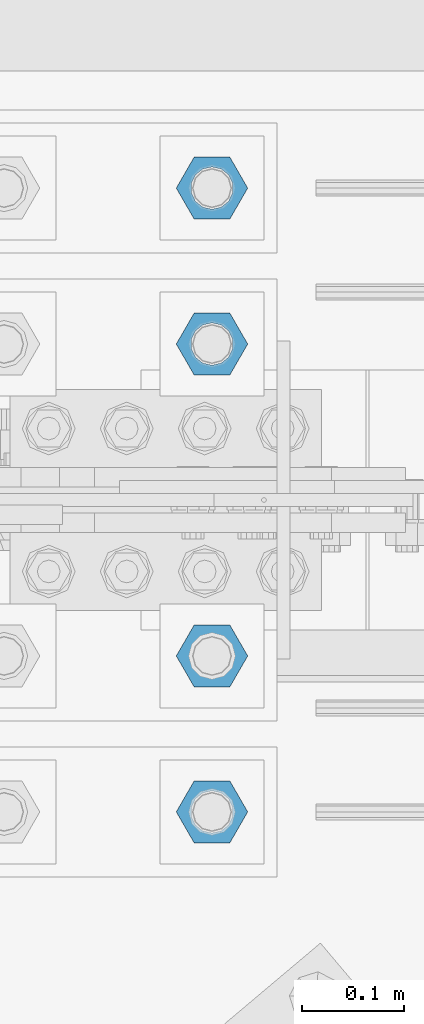
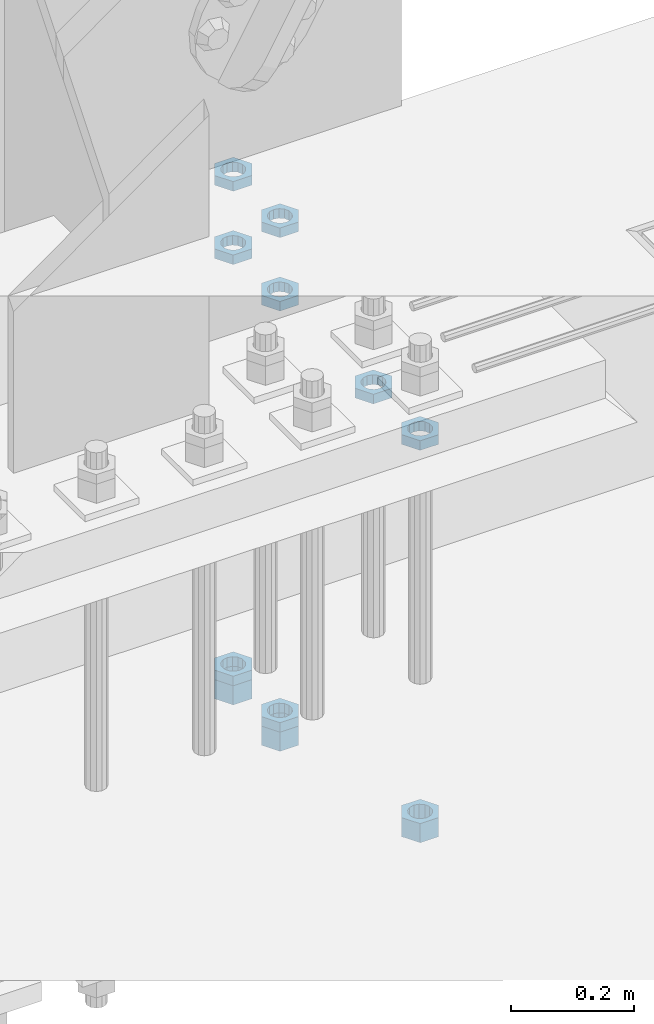
# One storey, part 2882 of 3843: 11 beams, 1 element without a shape of its own.
"""IFC2X3 building model written with IfcOpenShell, lengths in millimetres."""

from ifc_helpers import new_model, si_unit, frame, origin_with_axes, place, context, subcontext, project, spatial, faceted_brep, material, type_object, element, aggregate, save


model = new_model("IFC2X3")

# Units and contexts
model_context = context("Model", 3, precision=1e-05, world=origin_with_axes())
body_context = subcontext(model_context, "Body", "Model", "MODEL_VIEW")
ifc_project = project(units=[si_unit("LENGTHUNIT", "METRE", prefix="MILLI"), si_unit("AREAUNIT", "SQUARE_METRE"), si_unit("VOLUMEUNIT", "CUBIC_METRE"), si_unit("MASSUNIT", "GRAM", prefix="KILO"), si_unit("TIMEUNIT", "SECOND"), si_unit("PLANEANGLEUNIT", "RADIAN"), si_unit("SOLIDANGLEUNIT", "STERADIAN"), si_unit("THERMODYNAMICTEMPERATUREUNIT", "DEGREE_CELSIUS"), si_unit("LUMINOUSINTENSITYUNIT", "LUMEN")], contexts=[model_context])

# Site, building, storey
site_placement = place(None, origin_with_axes())
site = spatial("IfcSite", under=ifc_project, at=site_placement, CompositionType="ELEMENT")
building_placement = place(site_placement, origin_with_axes())
building = spatial("IfcBuilding", under=site, at=building_placement, Name="Undefined", CompositionType="ELEMENT")
storey_placement = place(building_placement, origin_with_axes())
storey = spatial("IfcBuildingStorey", under=building, at=storey_placement, Name="Undefined", CompositionType="ELEMENT", Elevation=0.0)

# Assembly, beams
assembly_placement = place(storey_placement, origin_with_axes())
assembly = element("IfcElementAssembly", 1, at=assembly_placement, inside=storey, Name="TEMPLATE", AssemblyPlace="NOTDEFINED", PredefinedType="RIGID_FRAME")
ifc_material = material(Name="STEEL/A572-50")
beam_type_1 = type_object("IfcBeamType", Name="1-1/2_HEAVY_HEX_NUT", PredefinedType="NOTDEFINED")
beam_1_placement = place(assembly_placement, frame((49504.6, 91909.9, 29298.9000015259), z_axis=(0.0, 1.0, 0.0), x_axis=(0.0, 0.0, -1.0)))
beam_1 = element("IfcBeam", 2, at=beam_1_placement, type_object=beam_type_1, material=ifc_material, Name="NUT", ObjectType="1-1/2_HEAVY_HEX_NUT", context=body_context, shape_type="Brep", body=[
    faceted_brep([(0.0, -34.9199981689453, 0.0), (0.0, -17.4599990844727, -30.25), (38.0999999999985, -17.4599990844727, -30.25), (38.0999999999985, -34.9199981689453, 0.0), (0.0, 17.4599990844727, -30.25), (38.0999999999985, 17.4599990844727, -30.25), (0.0, 34.9199981689453, 0.0), (38.0999999999985, 34.9199981689453, 0.0), (0.0, 17.4599990844727, 30.25), (38.0999999999985, 17.4599990844727, 30.25), (0.0, -17.4599990844727, 30.25), (38.0999999999985, -17.4599990844727, 30.25), (0.0, 0.0, 20.6399993896484), (0.0, 8.9553601105581, 18.5959968835959), (38.0999999999985, 8.9553601105581, 18.5959968835959), (38.0999999999985, 0.0, 20.6399993896484), (0.0, 16.1370013209525, 12.8688291298167), (38.0999999999985, 16.1370013209525, 12.8688291298167), (0.0, 20.1225115123816, 4.59283194104501), (38.0999999999985, 20.1225115123816, 4.59283194104501), (0.0, 20.1225115123816, -4.59283194104501), (38.0999999999985, 20.1225115123816, -4.59283194104501), (0.0, 16.1370013209525, -12.8688291298167), (38.0999999999985, 16.1370013209525, -12.8688291298167), (0.0, 8.9553601105581, -18.5959968835959), (38.0999999999985, 8.9553601105581, -18.5959968835959), (0.0, 0.0, -20.6399993896484), (38.0999999999985, 0.0, -20.6399993896484), (0.0, -8.9553601105581, -18.5959968835959), (38.0999999999985, -8.9553601105581, -18.5959968835959), (0.0, -16.1370013209525, -12.8688291298167), (38.0999999999985, -16.1370013209525, -12.8688291298167), (0.0, -20.1225115123816, -4.59283194104501), (38.0999999999985, -20.1225115123816, -4.59283194104501), (0.0, -20.1225115123816, 4.59283194104501), (38.0999999999985, -20.1225115123816, 4.59283194104501), (0.0, -16.1370013209525, 12.8688291298167), (38.0999999999985, -16.1370013209525, 12.8688291298167), (0.0, -8.9553601105581, 18.5959968835959), (38.0999999999985, -8.9553601105581, 18.5959968835959)], [[[0, 1, 2, 3]], [[1, 4, 5, 2]], [[4, 6, 7, 5]], [[6, 8, 9, 7]], [[8, 10, 11, 9]], [[10, 0, 3, 11]], [[12, 13, 14, 15]], [[13, 16, 17, 14]], [[16, 18, 19, 17]], [[18, 20, 21, 19]], [[20, 22, 23, 21]], [[22, 24, 25, 23]], [[24, 26, 27, 25]], [[26, 28, 29, 27]], [[28, 30, 31, 29]], [[30, 32, 33, 31]], [[32, 34, 35, 33]], [[34, 36, 37, 35]], [[36, 38, 39, 37]], [[38, 12, 15, 39]], [[5, 7, 9, 11, 3, 2], [17, 19, 21, 23, 25, 27, 29, 31, 33, 35, 37, 39, 15, 14]], [[10, 8, 6, 4, 1, 0], [38, 36, 34, 32, 30, 28, 26, 24, 22, 20, 18, 16, 13, 12]]]),
])
beam_2_placement = place(assembly_placement, frame((49504.6, 92519.5, 29203.6500015259), z_axis=(0.0, 1.0, 0.0), x_axis=(0.0, 0.0, -1.0)))
beam_2 = element("IfcBeam", 3, at=beam_2_placement, type_object=beam_type_1, material=ifc_material, Name="NUT", ObjectType="1-1/2_HEAVY_HEX_NUT", context=body_context, shape_type="Brep", body=[
    faceted_brep([(0.0, -34.9199981689453, 0.0), (0.0, -17.4599990844727, -30.25), (38.0999999999985, -17.4599990844727, -30.25), (38.0999999999985, -34.9199981689453, 0.0), (0.0, 17.4599990844727, -30.25), (38.0999999999985, 17.4599990844727, -30.25), (0.0, 34.9199981689453, 0.0), (38.0999999999985, 34.9199981689453, 0.0), (0.0, 17.4599990844727, 30.25), (38.0999999999985, 17.4599990844727, 30.25), (0.0, -17.4599990844727, 30.25), (38.0999999999985, -17.4599990844727, 30.25), (0.0, 0.0, 20.6399993896484), (0.0, 8.9553601105581, 18.5959968835959), (38.0999999999985, 8.9553601105581, 18.5959968835959), (38.0999999999985, 0.0, 20.6399993896484), (0.0, 16.1370013209525, 12.8688291298167), (38.0999999999985, 16.1370013209525, 12.8688291298167), (0.0, 20.1225115123816, 4.59283194104501), (38.0999999999985, 20.1225115123816, 4.59283194104501), (0.0, 20.1225115123816, -4.59283194104501), (38.0999999999985, 20.1225115123816, -4.59283194104501), (0.0, 16.1370013209525, -12.8688291298167), (38.0999999999985, 16.1370013209525, -12.8688291298167), (0.0, 8.9553601105581, -18.5959968835959), (38.0999999999985, 8.9553601105581, -18.5959968835959), (0.0, 0.0, -20.6399993896484), (38.0999999999985, 0.0, -20.6399993896484), (0.0, -8.9553601105581, -18.5959968835959), (38.0999999999985, -8.9553601105581, -18.5959968835959), (0.0, -16.1370013209525, -12.8688291298167), (38.0999999999985, -16.1370013209525, -12.8688291298167), (0.0, -20.1225115123816, -4.59283194104501), (38.0999999999985, -20.1225115123816, -4.59283194104501), (0.0, -20.1225115123816, 4.59283194104501), (38.0999999999985, -20.1225115123816, 4.59283194104501), (0.0, -16.1370013209525, 12.8688291298167), (38.0999999999985, -16.1370013209525, 12.8688291298167), (0.0, -8.9553601105581, 18.5959968835959), (38.0999999999985, -8.9553601105581, 18.5959968835959)], [[[0, 1, 2, 3]], [[1, 4, 5, 2]], [[4, 6, 7, 5]], [[6, 8, 9, 7]], [[8, 10, 11, 9]], [[10, 0, 3, 11]], [[12, 13, 14, 15]], [[13, 16, 17, 14]], [[16, 18, 19, 17]], [[18, 20, 21, 19]], [[20, 22, 23, 21]], [[22, 24, 25, 23]], [[24, 26, 27, 25]], [[26, 28, 29, 27]], [[28, 30, 31, 29]], [[30, 32, 33, 31]], [[32, 34, 35, 33]], [[34, 36, 37, 35]], [[36, 38, 39, 37]], [[38, 12, 15, 39]], [[5, 7, 9, 11, 3, 2], [17, 19, 21, 23, 25, 27, 29, 31, 33, 35, 37, 39, 15, 14]], [[10, 8, 6, 4, 1, 0], [38, 36, 34, 32, 30, 28, 26, 24, 22, 20, 18, 16, 13, 12]]]),
])
beam_3_placement = place(assembly_placement, frame((49504.6, 92367.1, 29203.6500015259), z_axis=(0.0, 1.0, 0.0), x_axis=(0.0, 0.0, -1.0)))
beam_3 = element("IfcBeam", 4, at=beam_3_placement, type_object=beam_type_1, material=ifc_material, Name="NUT", ObjectType="1-1/2_HEAVY_HEX_NUT", context=body_context, shape_type="Brep", body=[
    faceted_brep([(0.0, -34.9199981689453, 0.0), (0.0, -17.4599990844727, -30.25), (38.0999999999985, -17.4599990844727, -30.25), (38.0999999999985, -34.9199981689453, 0.0), (0.0, 17.4599990844727, -30.25), (38.0999999999985, 17.4599990844727, -30.25), (0.0, 34.9199981689453, 0.0), (38.0999999999985, 34.9199981689453, 0.0), (0.0, 17.4599990844727, 30.25), (38.0999999999985, 17.4599990844727, 30.25), (0.0, -17.4599990844727, 30.25), (38.0999999999985, -17.4599990844727, 30.25), (0.0, 0.0, 20.6399993896484), (0.0, 8.9553601105581, 18.5959968835959), (38.0999999999985, 8.9553601105581, 18.5959968835959), (38.0999999999985, 0.0, 20.6399993896484), (0.0, 16.1370013209525, 12.8688291298167), (38.0999999999985, 16.1370013209525, 12.8688291298167), (0.0, 20.1225115123816, 4.59283194104501), (38.0999999999985, 20.1225115123816, 4.59283194104501), (0.0, 20.1225115123816, -4.59283194104501), (38.0999999999985, 20.1225115123816, -4.59283194104501), (0.0, 16.1370013209525, -12.8688291298167), (38.0999999999985, 16.1370013209525, -12.8688291298167), (0.0, 8.9553601105581, -18.5959968835959), (38.0999999999985, 8.9553601105581, -18.5959968835959), (0.0, 0.0, -20.6399993896484), (38.0999999999985, 0.0, -20.6399993896484), (0.0, -8.9553601105581, -18.5959968835959), (38.0999999999985, -8.9553601105581, -18.5959968835959), (0.0, -16.1370013209525, -12.8688291298167), (38.0999999999985, -16.1370013209525, -12.8688291298167), (0.0, -20.1225115123816, -4.59283194104501), (38.0999999999985, -20.1225115123816, -4.59283194104501), (0.0, -20.1225115123816, 4.59283194104501), (38.0999999999985, -20.1225115123816, 4.59283194104501), (0.0, -16.1370013209525, 12.8688291298167), (38.0999999999985, -16.1370013209525, 12.8688291298167), (0.0, -8.9553601105581, 18.5959968835959), (38.0999999999985, -8.9553601105581, 18.5959968835959)], [[[0, 1, 2, 3]], [[1, 4, 5, 2]], [[4, 6, 7, 5]], [[6, 8, 9, 7]], [[8, 10, 11, 9]], [[10, 0, 3, 11]], [[12, 13, 14, 15]], [[13, 16, 17, 14]], [[16, 18, 19, 17]], [[18, 20, 21, 19]], [[20, 22, 23, 21]], [[22, 24, 25, 23]], [[24, 26, 27, 25]], [[26, 28, 29, 27]], [[28, 30, 31, 29]], [[30, 32, 33, 31]], [[32, 34, 35, 33]], [[34, 36, 37, 35]], [[36, 38, 39, 37]], [[38, 12, 15, 39]], [[5, 7, 9, 11, 3, 2], [17, 19, 21, 23, 25, 27, 29, 31, 33, 35, 37, 39, 15, 14]], [[10, 8, 6, 4, 1, 0], [38, 36, 34, 32, 30, 28, 26, 24, 22, 20, 18, 16, 13, 12]]]),
])
beam_type_2 = type_object("IfcBeamType", Name="1-1/2_HALF_NUT", PredefinedType="NOTDEFINED")
beam_4_placement = place(assembly_placement, frame((49504.600012207, 92519.5, 30060.9), z_axis=(0.0, 1.0, 0.0), x_axis=(0.0, 0.0, -1.0)))
beam_4 = element("IfcBeam", 5, at=beam_4_placement, type_object=beam_type_2, material=ifc_material, Name="NUT", ObjectType="1-1/2_HALF_NUT", context=body_context, shape_type="Brep", body=[
    faceted_brep([(0.0, -34.9199981689453, 0.0), (0.0, -17.4599990844727, -30.25), (19.0500000000029, -17.4599990844727, -30.25), (19.0500000000029, -34.9199981689453, 0.0), (0.0, 17.4599990844727, -30.25), (19.0500000000029, 17.4599990844727, -30.25), (0.0, 34.9199981689453, 0.0), (19.0500000000029, 34.9199981689453, 0.0), (0.0, 17.4599990844727, 30.25), (19.0500000000029, 17.4599990844727, 30.25), (0.0, -17.4599990844727, 30.25), (19.0500000000029, -17.4599990844727, 30.25), (0.0, 0.0, 20.6399993896484), (0.0, 8.9553601105581, 18.5959968835959), (19.0500000000029, 8.95536011056538, 18.5959968835959), (19.0500000000029, 0.0, 20.6399993896484), (0.0, 16.1370013209525, 12.8688291298167), (19.0500000000029, 16.1370013209489, 12.8688291298167), (0.0, 20.1225115123816, 4.59283194104501), (19.0500000000029, 20.1225115123852, 4.59283194104501), (0.0, 20.1225115123816, -4.59283194104501), (19.0500000000029, 20.1225115123852, -4.59283194104501), (0.0, 16.1370013209525, -12.8688291298167), (19.0500000000029, 16.1370013209489, -12.8688291298167), (0.0, 8.9553601105581, -18.5959968835959), (19.0500000000029, 8.95536011056538, -18.5959968835959), (0.0, 0.0, -20.6399993896484), (19.0500000000029, 0.0, -20.6399993896484), (0.0, -8.9553601105581, -18.5959968835959), (19.0500000000029, -8.95536011056538, -18.5959968835959), (0.0, -16.1370013209525, -12.8688291298167), (19.0500000000029, -16.1370013209489, -12.8688291298167), (0.0, -20.1225115123816, -4.59283194104501), (19.0500000000029, -20.1225115123852, -4.59283194104501), (0.0, -20.1225115123816, 4.59283194104501), (19.0500000000029, -20.1225115123852, 4.59283194104501), (0.0, -16.1370013209525, 12.8688291298167), (19.0500000000029, -16.1370013209489, 12.8688291298167), (0.0, -8.9553601105581, 18.5959968835959), (19.0500000000029, -8.95536011056538, 18.5959968835959)], [[[0, 1, 2, 3]], [[1, 4, 5, 2]], [[4, 6, 7, 5]], [[6, 8, 9, 7]], [[8, 10, 11, 9]], [[10, 0, 3, 11]], [[12, 13, 14, 15]], [[13, 16, 17, 14]], [[16, 18, 19, 17]], [[18, 20, 21, 19]], [[20, 22, 23, 21]], [[22, 24, 25, 23]], [[24, 26, 27, 25]], [[26, 28, 29, 27]], [[28, 30, 31, 29]], [[30, 32, 33, 31]], [[32, 34, 35, 33]], [[34, 36, 37, 35]], [[36, 38, 39, 37]], [[38, 12, 15, 39]], [[5, 7, 9, 11, 3, 2], [17, 19, 21, 23, 25, 27, 29, 31, 33, 35, 37, 39, 15, 14]], [[10, 8, 6, 4, 1, 0], [38, 36, 34, 32, 30, 28, 26, 24, 22, 20, 18, 16, 13, 12]]]),
])
beam_5_placement = place(assembly_placement, frame((49504.600012207, 92367.1, 30060.9), z_axis=(0.0, 1.0, 0.0), x_axis=(0.0, 0.0, -1.0)))
beam_5 = element("IfcBeam", 6, at=beam_5_placement, type_object=beam_type_2, material=ifc_material, Name="NUT", ObjectType="1-1/2_HALF_NUT", context=body_context, shape_type="Brep", body=[
    faceted_brep([(0.0, -34.9199981689453, 0.0), (0.0, -17.4599990844727, -30.25), (19.0500000000029, -17.4599990844727, -30.25), (19.0500000000029, -34.9199981689453, 0.0), (0.0, 17.4599990844727, -30.25), (19.0500000000029, 17.4599990844727, -30.25), (0.0, 34.9199981689453, 0.0), (19.0500000000029, 34.9199981689453, 0.0), (0.0, 17.4599990844727, 30.25), (19.0500000000029, 17.4599990844727, 30.25), (0.0, -17.4599990844727, 30.25), (19.0500000000029, -17.4599990844727, 30.25), (0.0, 0.0, 20.6399993896484), (0.0, 8.9553601105581, 18.5959968835959), (19.0500000000029, 8.95536011056538, 18.5959968835959), (19.0500000000029, 0.0, 20.6399993896484), (0.0, 16.1370013209525, 12.8688291298167), (19.0500000000029, 16.1370013209489, 12.8688291298167), (0.0, 20.1225115123816, 4.59283194104501), (19.0500000000029, 20.1225115123852, 4.59283194104501), (0.0, 20.1225115123816, -4.59283194104501), (19.0500000000029, 20.1225115123852, -4.59283194104501), (0.0, 16.1370013209525, -12.8688291298167), (19.0500000000029, 16.1370013209489, -12.8688291298167), (0.0, 8.9553601105581, -18.5959968835959), (19.0500000000029, 8.95536011056538, -18.5959968835959), (0.0, 0.0, -20.6399993896484), (19.0500000000029, 0.0, -20.6399993896484), (0.0, -8.9553601105581, -18.5959968835959), (19.0500000000029, -8.95536011056538, -18.5959968835959), (0.0, -16.1370013209525, -12.8688291298167), (19.0500000000029, -16.1370013209489, -12.8688291298167), (0.0, -20.1225115123816, -4.59283194104501), (19.0500000000029, -20.1225115123852, -4.59283194104501), (0.0, -20.1225115123816, 4.59283194104501), (19.0500000000029, -20.1225115123852, 4.59283194104501), (0.0, -16.1370013209525, 12.8688291298167), (19.0500000000029, -16.1370013209489, 12.8688291298167), (0.0, -8.9553601105581, 18.5959968835959), (19.0500000000029, -8.95536011056538, 18.5959968835959)], [[[0, 1, 2, 3]], [[1, 4, 5, 2]], [[4, 6, 7, 5]], [[6, 8, 9, 7]], [[8, 10, 11, 9]], [[10, 0, 3, 11]], [[12, 13, 14, 15]], [[13, 16, 17, 14]], [[16, 18, 19, 17]], [[18, 20, 21, 19]], [[20, 22, 23, 21]], [[22, 24, 25, 23]], [[24, 26, 27, 25]], [[26, 28, 29, 27]], [[28, 30, 31, 29]], [[30, 32, 33, 31]], [[32, 34, 35, 33]], [[34, 36, 37, 35]], [[36, 38, 39, 37]], [[38, 12, 15, 39]], [[5, 7, 9, 11, 3, 2], [17, 19, 21, 23, 25, 27, 29, 31, 33, 35, 37, 39, 15, 14]], [[10, 8, 6, 4, 1, 0], [38, 36, 34, 32, 30, 28, 26, 24, 22, 20, 18, 16, 13, 12]]]),
])
beam_6_placement = place(assembly_placement, frame((49504.600012207, 92062.3, 30060.9), z_axis=(0.0, 1.0, 0.0), x_axis=(0.0, 0.0, -1.0)))
beam_6 = element("IfcBeam", 7, at=beam_6_placement, type_object=beam_type_2, material=ifc_material, Name="NUT", ObjectType="1-1/2_HALF_NUT", context=body_context, shape_type="Brep", body=[
    faceted_brep([(0.0, -34.9199981689453, 0.0), (0.0, -17.4599990844727, -30.25), (19.0500000000029, -17.4599990844727, -30.25), (19.0500000000029, -34.9199981689453, 0.0), (0.0, 17.4599990844727, -30.25), (19.0500000000029, 17.4599990844727, -30.25), (0.0, 34.9199981689453, 0.0), (19.0500000000029, 34.9199981689453, 0.0), (0.0, 17.4599990844727, 30.25), (19.0500000000029, 17.4599990844727, 30.25), (0.0, -17.4599990844727, 30.25), (19.0500000000029, -17.4599990844727, 30.25), (0.0, 0.0, 20.6399993896484), (0.0, 8.9553601105581, 18.5959968835959), (19.0500000000029, 8.95536011056538, 18.5959968835959), (19.0500000000029, 0.0, 20.6399993896484), (0.0, 16.1370013209525, 12.8688291298167), (19.0500000000029, 16.1370013209489, 12.8688291298167), (0.0, 20.1225115123816, 4.59283194104501), (19.0500000000029, 20.1225115123852, 4.59283194104501), (0.0, 20.1225115123816, -4.59283194104501), (19.0500000000029, 20.1225115123852, -4.59283194104501), (0.0, 16.1370013209525, -12.8688291298167), (19.0500000000029, 16.1370013209489, -12.8688291298167), (0.0, 8.9553601105581, -18.5959968835959), (19.0500000000029, 8.95536011056538, -18.5959968835959), (0.0, 0.0, -20.6399993896484), (19.0500000000029, 0.0, -20.6399993896484), (0.0, -8.9553601105581, -18.5959968835959), (19.0500000000029, -8.95536011056538, -18.5959968835959), (0.0, -16.1370013209525, -12.8688291298167), (19.0500000000029, -16.1370013209489, -12.8688291298167), (0.0, -20.1225115123816, -4.59283194104501), (19.0500000000029, -20.1225115123852, -4.59283194104501), (0.0, -20.1225115123816, 4.59283194104501), (19.0500000000029, -20.1225115123852, 4.59283194104501), (0.0, -16.1370013209525, 12.8688291298167), (19.0500000000029, -16.1370013209489, 12.8688291298167), (0.0, -8.9553601105581, 18.5959968835959), (19.0500000000029, -8.95536011056538, 18.5959968835959)], [[[0, 1, 2, 3]], [[1, 4, 5, 2]], [[4, 6, 7, 5]], [[6, 8, 9, 7]], [[8, 10, 11, 9]], [[10, 0, 3, 11]], [[12, 13, 14, 15]], [[13, 16, 17, 14]], [[16, 18, 19, 17]], [[18, 20, 21, 19]], [[20, 22, 23, 21]], [[22, 24, 25, 23]], [[24, 26, 27, 25]], [[26, 28, 29, 27]], [[28, 30, 31, 29]], [[30, 32, 33, 31]], [[32, 34, 35, 33]], [[34, 36, 37, 35]], [[36, 38, 39, 37]], [[38, 12, 15, 39]], [[5, 7, 9, 11, 3, 2], [17, 19, 21, 23, 25, 27, 29, 31, 33, 35, 37, 39, 15, 14]], [[10, 8, 6, 4, 1, 0], [38, 36, 34, 32, 30, 28, 26, 24, 22, 20, 18, 16, 13, 12]]]),
])
beam_7_placement = place(assembly_placement, frame((49504.600012207, 91909.9, 30060.9), z_axis=(0.0, 1.0, 0.0), x_axis=(0.0, 0.0, -1.0)))
beam_7 = element("IfcBeam", 8, at=beam_7_placement, type_object=beam_type_2, material=ifc_material, Name="NUT", ObjectType="1-1/2_HALF_NUT", context=body_context, shape_type="Brep", body=[
    faceted_brep([(0.0, -34.9199981689453, 0.0), (0.0, -17.4599990844727, -30.25), (19.0500000000029, -17.4599990844727, -30.25), (19.0500000000029, -34.9199981689453, 0.0), (0.0, 17.4599990844727, -30.25), (19.0500000000029, 17.4599990844727, -30.25), (0.0, 34.9199981689453, 0.0), (19.0500000000029, 34.9199981689453, 0.0), (0.0, 17.4599990844727, 30.25), (19.0500000000029, 17.4599990844727, 30.25), (0.0, -17.4599990844727, 30.25), (19.0500000000029, -17.4599990844727, 30.25), (0.0, 0.0, 20.6399993896484), (0.0, 8.9553601105581, 18.5959968835959), (19.0500000000029, 8.95536011056538, 18.5959968835959), (19.0500000000029, 0.0, 20.6399993896484), (0.0, 16.1370013209525, 12.8688291298167), (19.0500000000029, 16.1370013209489, 12.8688291298167), (0.0, 20.1225115123816, 4.59283194104501), (19.0500000000029, 20.1225115123852, 4.59283194104501), (0.0, 20.1225115123816, -4.59283194104501), (19.0500000000029, 20.1225115123852, -4.59283194104501), (0.0, 16.1370013209525, -12.8688291298167), (19.0500000000029, 16.1370013209489, -12.8688291298167), (0.0, 8.9553601105581, -18.5959968835959), (19.0500000000029, 8.95536011056538, -18.5959968835959), (0.0, 0.0, -20.6399993896484), (19.0500000000029, 0.0, -20.6399993896484), (0.0, -8.9553601105581, -18.5959968835959), (19.0500000000029, -8.95536011056538, -18.5959968835959), (0.0, -16.1370013209525, -12.8688291298167), (19.0500000000029, -16.1370013209489, -12.8688291298167), (0.0, -20.1225115123816, -4.59283194104501), (19.0500000000029, -20.1225115123852, -4.59283194104501), (0.0, -20.1225115123816, 4.59283194104501), (19.0500000000029, -20.1225115123852, 4.59283194104501), (0.0, -16.1370013209525, 12.8688291298167), (19.0500000000029, -16.1370013209489, 12.8688291298167), (0.0, -8.9553601105581, 18.5959968835959), (19.0500000000029, -8.95536011056538, 18.5959968835959)], [[[0, 1, 2, 3]], [[1, 4, 5, 2]], [[4, 6, 7, 5]], [[6, 8, 9, 7]], [[8, 10, 11, 9]], [[10, 0, 3, 11]], [[12, 13, 14, 15]], [[13, 16, 17, 14]], [[16, 18, 19, 17]], [[18, 20, 21, 19]], [[20, 22, 23, 21]], [[22, 24, 25, 23]], [[24, 26, 27, 25]], [[26, 28, 29, 27]], [[28, 30, 31, 29]], [[30, 32, 33, 31]], [[32, 34, 35, 33]], [[34, 36, 37, 35]], [[36, 38, 39, 37]], [[38, 12, 15, 39]], [[5, 7, 9, 11, 3, 2], [17, 19, 21, 23, 25, 27, 29, 31, 33, 35, 37, 39, 15, 14]], [[10, 8, 6, 4, 1, 0], [38, 36, 34, 32, 30, 28, 26, 24, 22, 20, 18, 16, 13, 12]]]),
])
beam_8_placement = place(assembly_placement, frame((49504.6, 92519.5, 29222.7000015259), z_axis=(0.0, 1.0, 0.0), x_axis=(0.0, 0.0, -1.0)))
beam_8 = element("IfcBeam", 9, at=beam_8_placement, type_object=beam_type_2, material=ifc_material, Name="NUT", ObjectType="1-1/2_HALF_NUT", context=body_context, shape_type="Brep", body=[
    faceted_brep([(0.0, -34.9199981689453, 0.0), (0.0, -17.4599990844727, -30.25), (19.0500000000029, -17.4599990844727, -30.25), (19.0500000000029, -34.9199981689453, 0.0), (0.0, 17.4599990844727, -30.25), (19.0500000000029, 17.4599990844727, -30.25), (0.0, 34.9199981689453, 0.0), (19.0500000000029, 34.9199981689453, 0.0), (0.0, 17.4599990844727, 30.25), (19.0500000000029, 17.4599990844727, 30.25), (0.0, -17.4599990844727, 30.25), (19.0500000000029, -17.4599990844727, 30.25), (0.0, 0.0, 20.6399993896484), (0.0, 8.9553601105581, 18.5959968835959), (19.0500000000029, 8.95536011056538, 18.5959968835959), (19.0500000000029, 0.0, 20.6399993896484), (0.0, 16.1370013209525, 12.8688291298167), (19.0500000000029, 16.1370013209489, 12.8688291298167), (0.0, 20.1225115123816, 4.59283194104501), (19.0500000000029, 20.1225115123852, 4.59283194104501), (0.0, 20.1225115123816, -4.59283194104501), (19.0500000000029, 20.1225115123852, -4.59283194104501), (0.0, 16.1370013209525, -12.8688291298167), (19.0500000000029, 16.1370013209489, -12.8688291298167), (0.0, 8.9553601105581, -18.5959968835959), (19.0500000000029, 8.95536011056538, -18.5959968835959), (0.0, 0.0, -20.6399993896484), (19.0500000000029, 0.0, -20.6399993896484), (0.0, -8.9553601105581, -18.5959968835959), (19.0500000000029, -8.95536011056538, -18.5959968835959), (0.0, -16.1370013209525, -12.8688291298167), (19.0500000000029, -16.1370013209489, -12.8688291298167), (0.0, -20.1225115123816, -4.59283194104501), (19.0500000000029, -20.1225115123852, -4.59283194104501), (0.0, -20.1225115123816, 4.59283194104501), (19.0500000000029, -20.1225115123852, 4.59283194104501), (0.0, -16.1370013209525, 12.8688291298167), (19.0500000000029, -16.1370013209489, 12.8688291298167), (0.0, -8.9553601105581, 18.5959968835959), (19.0500000000029, -8.95536011056538, 18.5959968835959)], [[[0, 1, 2, 3]], [[1, 4, 5, 2]], [[4, 6, 7, 5]], [[6, 8, 9, 7]], [[8, 10, 11, 9]], [[10, 0, 3, 11]], [[12, 13, 14, 15]], [[13, 16, 17, 14]], [[16, 18, 19, 17]], [[18, 20, 21, 19]], [[20, 22, 23, 21]], [[22, 24, 25, 23]], [[24, 26, 27, 25]], [[26, 28, 29, 27]], [[28, 30, 31, 29]], [[30, 32, 33, 31]], [[32, 34, 35, 33]], [[34, 36, 37, 35]], [[36, 38, 39, 37]], [[38, 12, 15, 39]], [[5, 7, 9, 11, 3, 2], [17, 19, 21, 23, 25, 27, 29, 31, 33, 35, 37, 39, 15, 14]], [[10, 8, 6, 4, 1, 0], [38, 36, 34, 32, 30, 28, 26, 24, 22, 20, 18, 16, 13, 12]]]),
])
beam_9_placement = place(assembly_placement, frame((49504.6, 92519.5, 30206.95), z_axis=(0.0, 1.0, 0.0), x_axis=(0.0, 0.0, -1.0)))
beam_9 = element("IfcBeam", 10, at=beam_9_placement, type_object=beam_type_2, material=ifc_material, Name="NUT", ObjectType="1-1/2_HALF_NUT", context=body_context, shape_type="Brep", body=[
    faceted_brep([(0.0, -34.9199981689453, 0.0), (0.0, -17.4599990844727, -30.25), (19.0500000000029, -17.4599990844727, -30.25), (19.0500000000029, -34.9199981689453, 0.0), (0.0, 17.4599990844727, -30.25), (19.0500000000029, 17.4599990844727, -30.25), (0.0, 34.9199981689453, 0.0), (19.0500000000029, 34.9199981689453, 0.0), (0.0, 17.4599990844727, 30.25), (19.0500000000029, 17.4599990844727, 30.25), (0.0, -17.4599990844727, 30.25), (19.0500000000029, -17.4599990844727, 30.25), (0.0, 0.0, 20.6399993896484), (0.0, 8.9553601105581, 18.5959968835959), (19.0500000000029, 8.95536011056538, 18.5959968835959), (19.0500000000029, 0.0, 20.6399993896484), (0.0, 16.1370013209525, 12.8688291298167), (19.0500000000029, 16.1370013209489, 12.8688291298167), (0.0, 20.1225115123816, 4.59283194104501), (19.0500000000029, 20.1225115123852, 4.59283194104501), (0.0, 20.1225115123816, -4.59283194104501), (19.0500000000029, 20.1225115123852, -4.59283194104501), (0.0, 16.1370013209525, -12.8688291298167), (19.0500000000029, 16.1370013209489, -12.8688291298167), (0.0, 8.9553601105581, -18.5959968835959), (19.0500000000029, 8.95536011056538, -18.5959968835959), (0.0, 0.0, -20.6399993896484), (19.0500000000029, 0.0, -20.6399993896484), (0.0, -8.9553601105581, -18.5959968835959), (19.0500000000029, -8.95536011056538, -18.5959968835959), (0.0, -16.1370013209525, -12.8688291298167), (19.0500000000029, -16.1370013209489, -12.8688291298167), (0.0, -20.1225115123816, -4.59283194104501), (19.0500000000029, -20.1225115123852, -4.59283194104501), (0.0, -20.1225115123816, 4.59283194104501), (19.0500000000029, -20.1225115123852, 4.59283194104501), (0.0, -16.1370013209525, 12.8688291298167), (19.0500000000029, -16.1370013209489, 12.8688291298167), (0.0, -8.9553601105581, 18.5959968835959), (19.0500000000029, -8.95536011056538, 18.5959968835959)], [[[0, 1, 2, 3]], [[1, 4, 5, 2]], [[4, 6, 7, 5]], [[6, 8, 9, 7]], [[8, 10, 11, 9]], [[10, 0, 3, 11]], [[12, 13, 14, 15]], [[13, 16, 17, 14]], [[16, 18, 19, 17]], [[18, 20, 21, 19]], [[20, 22, 23, 21]], [[22, 24, 25, 23]], [[24, 26, 27, 25]], [[26, 28, 29, 27]], [[28, 30, 31, 29]], [[30, 32, 33, 31]], [[32, 34, 35, 33]], [[34, 36, 37, 35]], [[36, 38, 39, 37]], [[38, 12, 15, 39]], [[5, 7, 9, 11, 3, 2], [17, 19, 21, 23, 25, 27, 29, 31, 33, 35, 37, 39, 15, 14]], [[10, 8, 6, 4, 1, 0], [38, 36, 34, 32, 30, 28, 26, 24, 22, 20, 18, 16, 13, 12]]]),
])
beam_10_placement = place(assembly_placement, frame((49504.6, 92367.1, 29222.7000015259), z_axis=(0.0, 1.0, 0.0), x_axis=(0.0, 0.0, -1.0)))
beam_10 = element("IfcBeam", 11, at=beam_10_placement, type_object=beam_type_2, material=ifc_material, Name="NUT", ObjectType="1-1/2_HALF_NUT", context=body_context, shape_type="Brep", body=[
    faceted_brep([(0.0, -34.9199981689453, 0.0), (0.0, -17.4599990844727, -30.25), (19.0500000000029, -17.4599990844727, -30.25), (19.0500000000029, -34.9199981689453, 0.0), (0.0, 17.4599990844727, -30.25), (19.0500000000029, 17.4599990844727, -30.25), (0.0, 34.9199981689453, 0.0), (19.0500000000029, 34.9199981689453, 0.0), (0.0, 17.4599990844727, 30.25), (19.0500000000029, 17.4599990844727, 30.25), (0.0, -17.4599990844727, 30.25), (19.0500000000029, -17.4599990844727, 30.25), (0.0, 0.0, 20.6399993896484), (0.0, 8.9553601105581, 18.5959968835959), (19.0500000000029, 8.95536011056538, 18.5959968835959), (19.0500000000029, 0.0, 20.6399993896484), (0.0, 16.1370013209525, 12.8688291298167), (19.0500000000029, 16.1370013209489, 12.8688291298167), (0.0, 20.1225115123816, 4.59283194104501), (19.0500000000029, 20.1225115123852, 4.59283194104501), (0.0, 20.1225115123816, -4.59283194104501), (19.0500000000029, 20.1225115123852, -4.59283194104501), (0.0, 16.1370013209525, -12.8688291298167), (19.0500000000029, 16.1370013209489, -12.8688291298167), (0.0, 8.9553601105581, -18.5959968835959), (19.0500000000029, 8.95536011056538, -18.5959968835959), (0.0, 0.0, -20.6399993896484), (19.0500000000029, 0.0, -20.6399993896484), (0.0, -8.9553601105581, -18.5959968835959), (19.0500000000029, -8.95536011056538, -18.5959968835959), (0.0, -16.1370013209525, -12.8688291298167), (19.0500000000029, -16.1370013209489, -12.8688291298167), (0.0, -20.1225115123816, -4.59283194104501), (19.0500000000029, -20.1225115123852, -4.59283194104501), (0.0, -20.1225115123816, 4.59283194104501), (19.0500000000029, -20.1225115123852, 4.59283194104501), (0.0, -16.1370013209525, 12.8688291298167), (19.0500000000029, -16.1370013209489, 12.8688291298167), (0.0, -8.9553601105581, 18.5959968835959), (19.0500000000029, -8.95536011056538, 18.5959968835959)], [[[0, 1, 2, 3]], [[1, 4, 5, 2]], [[4, 6, 7, 5]], [[6, 8, 9, 7]], [[8, 10, 11, 9]], [[10, 0, 3, 11]], [[12, 13, 14, 15]], [[13, 16, 17, 14]], [[16, 18, 19, 17]], [[18, 20, 21, 19]], [[20, 22, 23, 21]], [[22, 24, 25, 23]], [[24, 26, 27, 25]], [[26, 28, 29, 27]], [[28, 30, 31, 29]], [[30, 32, 33, 31]], [[32, 34, 35, 33]], [[34, 36, 37, 35]], [[36, 38, 39, 37]], [[38, 12, 15, 39]], [[5, 7, 9, 11, 3, 2], [17, 19, 21, 23, 25, 27, 29, 31, 33, 35, 37, 39, 15, 14]], [[10, 8, 6, 4, 1, 0], [38, 36, 34, 32, 30, 28, 26, 24, 22, 20, 18, 16, 13, 12]]]),
])
beam_11_placement = place(assembly_placement, frame((49504.6, 92367.1, 30206.95), z_axis=(0.0, 1.0, 0.0), x_axis=(0.0, 0.0, -1.0)))
beam_11 = element("IfcBeam", 12, at=beam_11_placement, type_object=beam_type_2, material=ifc_material, Name="NUT", ObjectType="1-1/2_HALF_NUT", context=body_context, shape_type="Brep", body=[
    faceted_brep([(0.0, -34.9199981689453, 0.0), (0.0, -17.4599990844727, -30.25), (19.0500000000029, -17.4599990844727, -30.25), (19.0500000000029, -34.9199981689453, 0.0), (0.0, 17.4599990844727, -30.25), (19.0500000000029, 17.4599990844727, -30.25), (0.0, 34.9199981689453, 0.0), (19.0500000000029, 34.9199981689453, 0.0), (0.0, 17.4599990844727, 30.25), (19.0500000000029, 17.4599990844727, 30.25), (0.0, -17.4599990844727, 30.25), (19.0500000000029, -17.4599990844727, 30.25), (0.0, 0.0, 20.6399993896484), (0.0, 8.9553601105581, 18.5959968835959), (19.0500000000029, 8.95536011056538, 18.5959968835959), (19.0500000000029, 0.0, 20.6399993896484), (0.0, 16.1370013209525, 12.8688291298167), (19.0500000000029, 16.1370013209489, 12.8688291298167), (0.0, 20.1225115123816, 4.59283194104501), (19.0500000000029, 20.1225115123852, 4.59283194104501), (0.0, 20.1225115123816, -4.59283194104501), (19.0500000000029, 20.1225115123852, -4.59283194104501), (0.0, 16.1370013209525, -12.8688291298167), (19.0500000000029, 16.1370013209489, -12.8688291298167), (0.0, 8.9553601105581, -18.5959968835959), (19.0500000000029, 8.95536011056538, -18.5959968835959), (0.0, 0.0, -20.6399993896484), (19.0500000000029, 0.0, -20.6399993896484), (0.0, -8.9553601105581, -18.5959968835959), (19.0500000000029, -8.95536011056538, -18.5959968835959), (0.0, -16.1370013209525, -12.8688291298167), (19.0500000000029, -16.1370013209489, -12.8688291298167), (0.0, -20.1225115123816, -4.59283194104501), (19.0500000000029, -20.1225115123852, -4.59283194104501), (0.0, -20.1225115123816, 4.59283194104501), (19.0500000000029, -20.1225115123852, 4.59283194104501), (0.0, -16.1370013209525, 12.8688291298167), (19.0500000000029, -16.1370013209489, 12.8688291298167), (0.0, -8.9553601105581, 18.5959968835959), (19.0500000000029, -8.95536011056538, 18.5959968835959)], [[[0, 1, 2, 3]], [[1, 4, 5, 2]], [[4, 6, 7, 5]], [[6, 8, 9, 7]], [[8, 10, 11, 9]], [[10, 0, 3, 11]], [[12, 13, 14, 15]], [[13, 16, 17, 14]], [[16, 18, 19, 17]], [[18, 20, 21, 19]], [[20, 22, 23, 21]], [[22, 24, 25, 23]], [[24, 26, 27, 25]], [[26, 28, 29, 27]], [[28, 30, 31, 29]], [[30, 32, 33, 31]], [[32, 34, 35, 33]], [[34, 36, 37, 35]], [[36, 38, 39, 37]], [[38, 12, 15, 39]], [[5, 7, 9, 11, 3, 2], [17, 19, 21, 23, 25, 27, 29, 31, 33, 35, 37, 39, 15, 14]], [[10, 8, 6, 4, 1, 0], [38, 36, 34, 32, 30, 28, 26, 24, 22, 20, 18, 16, 13, 12]]]),
])
aggregate(assembly, [beam_1, beam_4, beam_5, beam_6, beam_7, beam_8, beam_2, beam_9, beam_10, beam_3, beam_11])

save(model, "model.ifc")
